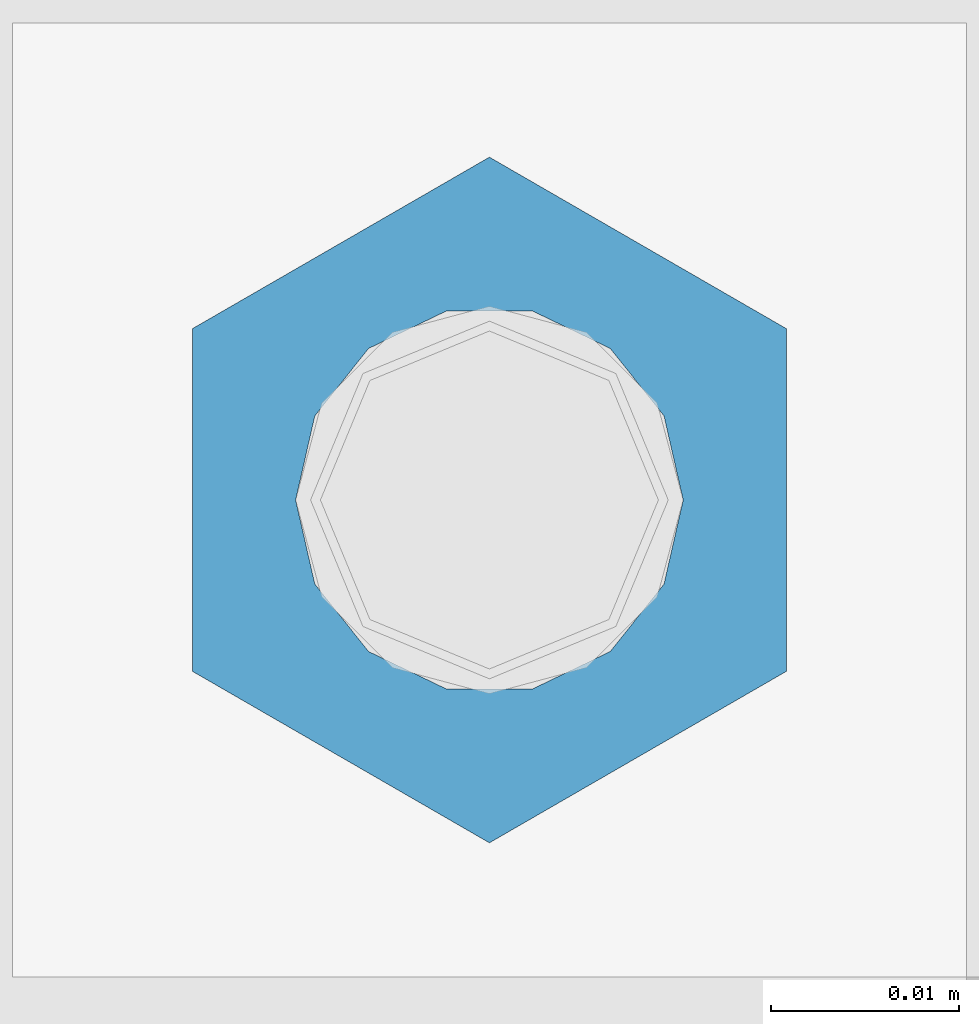
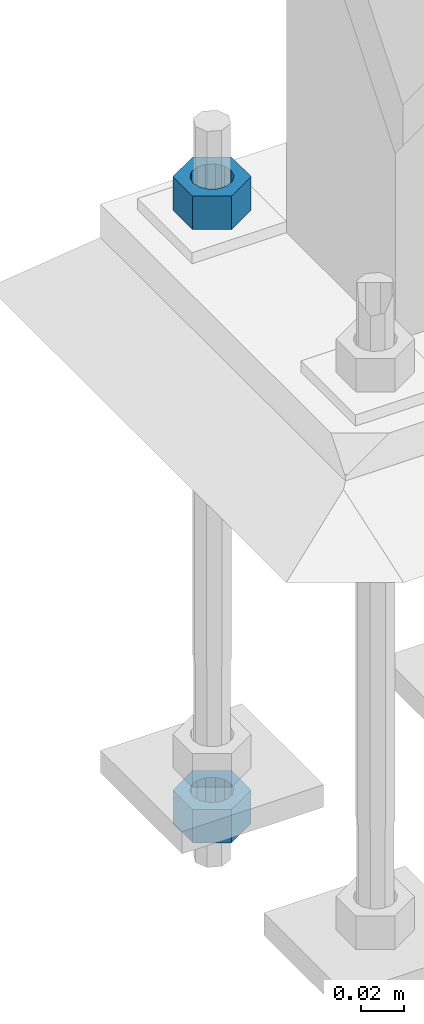
# One storey, part 1698 of 3843: 2 columns, 1 element without a shape of its own.
"""IFC2X3 building model written with IfcOpenShell, lengths in millimetres."""

from ifc_helpers import new_model, si_unit, frame, origin_with_axes, place, context, subcontext, project, spatial, faceted_brep, material, type_object, element, aggregate, save


model = new_model("IFC2X3")

# Units and contexts
model_context = context("Model", 3, precision=1e-05, world=origin_with_axes())
body_context = subcontext(model_context, "Body", "Model", "MODEL_VIEW")
ifc_project = project(units=[si_unit("LENGTHUNIT", "METRE", prefix="MILLI"), si_unit("AREAUNIT", "SQUARE_METRE"), si_unit("VOLUMEUNIT", "CUBIC_METRE"), si_unit("MASSUNIT", "GRAM", prefix="KILO"), si_unit("TIMEUNIT", "SECOND"), si_unit("PLANEANGLEUNIT", "RADIAN"), si_unit("SOLIDANGLEUNIT", "STERADIAN"), si_unit("THERMODYNAMICTEMPERATUREUNIT", "DEGREE_CELSIUS"), si_unit("LUMINOUSINTENSITYUNIT", "LUMEN")], contexts=[model_context])

# Site, building, storey
site_placement = place(None, origin_with_axes())
site = spatial("IfcSite", under=ifc_project, at=site_placement, CompositionType="ELEMENT")
building_placement = place(site_placement, origin_with_axes())
building = spatial("IfcBuilding", under=site, at=building_placement, Name="Undefined", CompositionType="ELEMENT")
storey_placement = place(building_placement, origin_with_axes())
storey = spatial("IfcBuildingStorey", under=building, at=storey_placement, Name="Undefined", CompositionType="ELEMENT", Elevation=0.0)

# Assembly, columns
assembly_placement = place(storey_placement, origin_with_axes())
assembly = element("IfcElementAssembly", 1, at=assembly_placement, inside=storey, Name="TEMPLATE", AssemblyPlace="NOTDEFINED", PredefinedType="RIGID_FRAME")
ifc_material = material(Name="STEEL/A36")
column_type = type_object("IfcColumnType", Name="3/4_HEAVY_HEX_NUT", PredefinedType="NOTDEFINED")
column_1_placement = place(assembly_placement, frame((38744.525, 84061.3, 30105.35), z_axis=(-1.0, 0.0, 0.0), x_axis=(0.0, 0.0, -1.0)))
column_1 = element("IfcColumn", 2, at=column_1_placement, type_object=column_type, material=ifc_material, Name="NUT", ObjectType="3/4_HEAVY_HEX_NUT", context=body_context, shape_type="Brep", body=[
    faceted_brep([(0.0, -18.2600002288818, 0.0), (0.0, -9.13000011444092, -15.8100004196167), (19.0500000000029, -9.13000011444092, -15.8100004196167), (19.0500000000029, -18.2600002288818, 0.0), (0.0, 9.13000011444092, -15.8100004196167), (19.0500000000029, 9.13000011444092, -15.8100004196167), (0.0, 18.2600002288818, 0.0), (19.0500000000029, 18.2600002288818, 0.0), (0.0, 9.13000011444092, 15.8100004196167), (19.0500000000029, 9.13000011444092, 15.8100004196167), (0.0, -9.13000011444092, 15.8100004196167), (19.0500000000029, -9.13000011444092, 15.8100004196167), (0.0, 0.0, 10.3199996948242), (0.0, 4.47768005527905, 9.29799844179797), (19.0500000000029, 4.47768005527905, 9.29799844179797), (19.0500000000029, 0.0, 10.3199996948242), (0.0, 8.06850066047627, 6.43441456490837), (19.0500000000029, 8.06850066047627, 6.43441456490837), (0.0, 10.0612557561908, 2.2964159705225), (19.0500000000029, 10.0612557561908, 2.2964159705225), (0.0, 10.0612557561908, -2.2964159705225), (19.0500000000029, 10.0612557561908, -2.2964159705225), (0.0, 8.06850066047627, -6.43441456490837), (19.0500000000029, 8.06850066047627, -6.43441456490837), (0.0, 4.47768005527905, -9.29799844179797), (19.0500000000029, 4.47768005527905, -9.29799844179797), (0.0, 0.0, -10.3199996948242), (19.0500000000029, 0.0, -10.3199996948242), (0.0, -4.47768005527905, -9.29799844179797), (19.0500000000029, -4.47768005527905, -9.29799844179797), (0.0, -8.06850066047627, -6.43441456490837), (19.0500000000029, -8.06850066047627, -6.43441456490837), (0.0, -10.0612557561908, -2.2964159705225), (19.0500000000029, -10.0612557561908, -2.2964159705225), (0.0, -10.0612557561908, 2.2964159705225), (19.0500000000029, -10.0612557561908, 2.2964159705225), (0.0, -8.06850066047627, 6.43441456490837), (19.0500000000029, -8.06850066047627, 6.43441456490837), (0.0, -4.47768005527905, 9.29799844179797), (19.0500000000029, -4.47768005527905, 9.29799844179797)], [[[0, 1, 2, 3]], [[1, 4, 5, 2]], [[4, 6, 7, 5]], [[6, 8, 9, 7]], [[8, 10, 11, 9]], [[10, 0, 3, 11]], [[12, 13, 14, 15]], [[13, 16, 17, 14]], [[16, 18, 19, 17]], [[18, 20, 21, 19]], [[20, 22, 23, 21]], [[22, 24, 25, 23]], [[24, 26, 27, 25]], [[26, 28, 29, 27]], [[28, 30, 31, 29]], [[30, 32, 33, 31]], [[32, 34, 35, 33]], [[34, 36, 37, 35]], [[36, 38, 39, 37]], [[38, 12, 15, 39]], [[5, 7, 9, 11, 3, 2], [17, 19, 21, 23, 25, 27, 29, 31, 33, 35, 37, 39, 15, 14]], [[10, 8, 6, 4, 1, 0], [38, 36, 34, 32, 30, 28, 26, 24, 22, 20, 18, 16, 13, 12]]]),
])
column_2_placement = place(assembly_placement, frame((38744.525, 84061.3, 29756.1), z_axis=(-1.0, 0.0, 0.0), x_axis=(0.0, 0.0, -1.0)))
column_2 = element("IfcColumn", 3, at=column_2_placement, type_object=column_type, material=ifc_material, Name="NUT", ObjectType="3/4_HEAVY_HEX_NUT", context=body_context, shape_type="Brep", body=[
    faceted_brep([(0.0, -18.2600002288818, 0.0), (0.0, -9.13000011444092, -15.8100004196167), (19.0500000000029, -9.13000011444092, -15.8100004196167), (19.0500000000029, -18.2600002288818, 0.0), (0.0, 9.13000011444092, -15.8100004196167), (19.0500000000029, 9.13000011444092, -15.8100004196167), (0.0, 18.2600002288818, 0.0), (19.0500000000029, 18.2600002288818, 0.0), (0.0, 9.13000011444092, 15.8100004196167), (19.0500000000029, 9.13000011444092, 15.8100004196167), (0.0, -9.13000011444092, 15.8100004196167), (19.0500000000029, -9.13000011444092, 15.8100004196167), (0.0, 0.0, 10.3199996948242), (0.0, 4.47768005527905, 9.29799844179797), (19.0500000000029, 4.47768005527905, 9.29799844179797), (19.0500000000029, 0.0, 10.3199996948242), (0.0, 8.06850066047627, 6.43441456490837), (19.0500000000029, 8.06850066047627, 6.43441456490837), (0.0, 10.0612557561908, 2.2964159705225), (19.0500000000029, 10.0612557561908, 2.2964159705225), (0.0, 10.0612557561908, -2.2964159705225), (19.0500000000029, 10.0612557561908, -2.2964159705225), (0.0, 8.06850066047627, -6.43441456490837), (19.0500000000029, 8.06850066047627, -6.43441456490837), (0.0, 4.47768005527905, -9.29799844179797), (19.0500000000029, 4.47768005527905, -9.29799844179797), (0.0, 0.0, -10.3199996948242), (19.0500000000029, 0.0, -10.3199996948242), (0.0, -4.47768005527905, -9.29799844179797), (19.0500000000029, -4.47768005527905, -9.29799844179797), (0.0, -8.06850066047627, -6.43441456490837), (19.0500000000029, -8.06850066047627, -6.43441456490837), (0.0, -10.0612557561908, -2.2964159705225), (19.0500000000029, -10.0612557561908, -2.2964159705225), (0.0, -10.0612557561908, 2.2964159705225), (19.0500000000029, -10.0612557561908, 2.2964159705225), (0.0, -8.06850066047627, 6.43441456490837), (19.0500000000029, -8.06850066047627, 6.43441456490837), (0.0, -4.47768005527905, 9.29799844179797), (19.0500000000029, -4.47768005527905, 9.29799844179797)], [[[0, 1, 2, 3]], [[1, 4, 5, 2]], [[4, 6, 7, 5]], [[6, 8, 9, 7]], [[8, 10, 11, 9]], [[10, 0, 3, 11]], [[12, 13, 14, 15]], [[13, 16, 17, 14]], [[16, 18, 19, 17]], [[18, 20, 21, 19]], [[20, 22, 23, 21]], [[22, 24, 25, 23]], [[24, 26, 27, 25]], [[26, 28, 29, 27]], [[28, 30, 31, 29]], [[30, 32, 33, 31]], [[32, 34, 35, 33]], [[34, 36, 37, 35]], [[36, 38, 39, 37]], [[38, 12, 15, 39]], [[5, 7, 9, 11, 3, 2], [17, 19, 21, 23, 25, 27, 29, 31, 33, 35, 37, 39, 15, 14]], [[10, 8, 6, 4, 1, 0], [38, 36, 34, 32, 30, 28, 26, 24, 22, 20, 18, 16, 13, 12]]]),
])
aggregate(assembly, [column_1, column_2])

save(model, "model.ifc")
